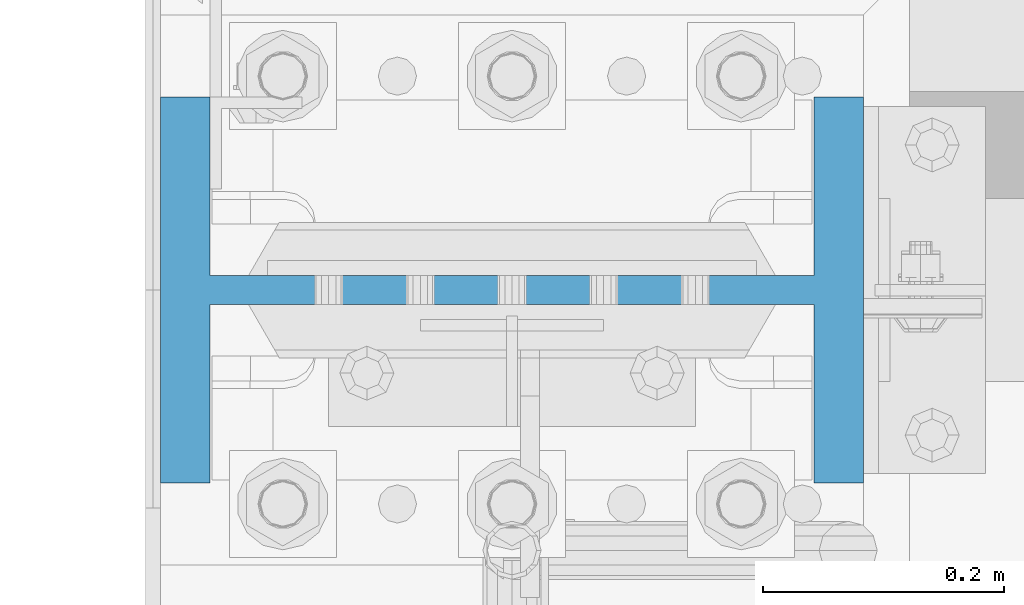
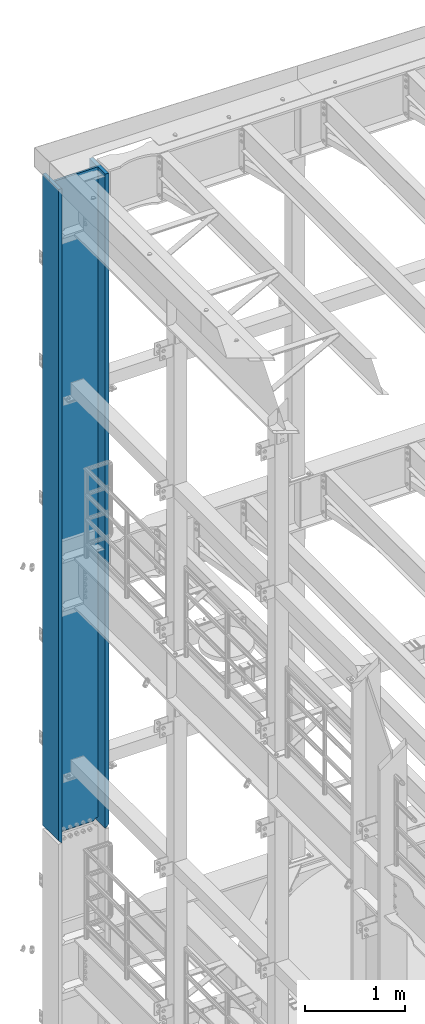
# One storey, part 749 of 1876: 1 column, 1 element without a shape of its own.
"""IFC2X3 building model written with IfcOpenShell, lengths in millimetres."""

from ifc_helpers import new_model, si_unit, frame, origin_with_axes, place, context, subcontext, project, spatial, faceted_brep, material, type_object, element, aggregate, save


model = new_model("IFC2X3")

# Units and contexts
model_context = context("Model", 3, precision=1e-05, world=origin_with_axes())
body_context = subcontext(model_context, "Body", "Model", "MODEL_VIEW")
ifc_project = project(units=[si_unit("LENGTHUNIT", "METRE", prefix="MILLI"), si_unit("AREAUNIT", "SQUARE_METRE"), si_unit("VOLUMEUNIT", "CUBIC_METRE"), si_unit("MASSUNIT", "GRAM", prefix="KILO"), si_unit("TIMEUNIT", "SECOND"), si_unit("PLANEANGLEUNIT", "RADIAN"), si_unit("SOLIDANGLEUNIT", "STERADIAN"), si_unit("THERMODYNAMICTEMPERATUREUNIT", "DEGREE_CELSIUS"), si_unit("LUMINOUSINTENSITYUNIT", "LUMEN")], contexts=[model_context])

# Site, building, storey
site_placement = place(None, origin_with_axes())
site = spatial("IfcSite", under=ifc_project, at=site_placement, CompositionType="ELEMENT")
building_placement = place(site_placement, origin_with_axes())
building = spatial("IfcBuilding", under=site, at=building_placement, Name="Undefined", CompositionType="ELEMENT")
storey_placement = place(building_placement, origin_with_axes())
storey = spatial("IfcBuildingStorey", under=building, at=storey_placement, Name="Undefined", CompositionType="ELEMENT", Elevation=0.0)

# Assembly, column
assembly_placement = place(storey_placement, origin_with_axes())
assembly = element("IfcElementAssembly", 1, at=assembly_placement, inside=storey, Name="COLUMN", AssemblyPlace="NOTDEFINED", PredefinedType="RIGID_FRAME")
ifc_material = material(Name="STEEL/A992")
column_type = type_object("IfcColumnType", Name="W21X201", PredefinedType="NOTDEFINED")
column_placement = place(assembly_placement, frame((0.0, 13716.0, 14528.8), z_axis=(-1.0, 0.0, 0.0), x_axis=(0.0, 0.0, 1.0)))
column = element("IfcColumn", 2, at=column_placement, type_object=column_type, material=ifc_material, Name="COLUMN", ObjectType="W21X201", context=body_context, shape_type="Brep", body=[
    faceted_brep([(26.9875007629398, -11.9062500000018, 204.691852352942), (25.7903180721823, -10.7090673092443, 203.891920453292), (6.35000000000036, 8.73125076293763, 200.02500076294), (6.35000000000036, 8.73125076293763, -200.02500076294), (25.7903188351211, -10.7090680721831, -203.891920453292), (26.9875007629398, -11.90625, -204.691851843163), (42.2710247077357, -11.90625, -214.903976055204), (42.2710247077357, 11.90625, -214.903976055204), (53.2830803096476, 11.90625, -231.384681927818), (53.2830803096476, -11.90625, -231.384681927818), (8026.4, -160.3375, 292.1), (8026.4, 160.3375, 292.1), (44.4500000000007, 160.3375, 292.1), (44.4500000000007, -160.3375, 292.1), (6.35000000000036, -160.3375, 250.825), (57.1499992370609, -160.3375, 250.825), (8026.4, -160.3375, 250.825), (6.35000000000036, -160.3375, 254.0), (6.35000000000036, -11.90625, 250.825), (6.35000000000036, 160.3375, 254.0), (6.35000000000036, 160.3375, 250.825), (6.35000000000036, 11.90625, 250.825), (6.35000000000036, 8.73125076293763, 250.825), (8026.4, 160.3375, 250.825), (57.1499992370609, 160.3375, 250.825), (57.1499992370609, 11.90625, 250.825), (8026.4, 11.90625, 250.825), (57.1499992370609, -11.90625, 250.825000000001), (53.2830795467089, 11.90625, 231.384681927818), (53.2830795467089, -11.90625, 231.384681927818), (26.9875007629398, -11.90625, 250.825), (8026.4, -11.90625, 250.825), (57.1499999999996, 160.3375, -250.825), (6.35000000000036, 160.3375, -250.825), (6.35000000000036, 11.90625, -250.825), (57.1499999999996, 11.90625, -250.825), (8026.4, 11.90625, -250.825), (8026.4, 160.3375, -250.825), (8026.4, 160.3375, -292.1), (8026.4, -160.3375, -292.1), (44.4500000000007, -160.3375, -292.1), (44.4500000000007, 160.3375, -292.1), (8026.4, -160.3375, -250.825), (57.1499999999996, -160.3375, -250.825), (6.35000000000036, -160.3375, -250.825), (6.35000000000036, -160.3375, -254.000000000001), (6.35000000000036, 160.3375, -254.000000000001), (8026.4, -11.90625, -250.825), (57.1499999999996, -11.90625, -250.825000000001), (26.9875007629398, -11.90625, -250.825), (6.35000000000036, -11.90625, -250.825), (6.35000000000036, 8.73125076293763, -250.825), (25.7903188351211, 11.90625, -203.891920453292), (6.35000000000036, 11.90625, -200.02500076294), (6.35000000000036, 11.90625, 200.02500076294), (25.7903180721823, 11.90625, 203.891920453292), (42.271023944797, 11.90625, 214.903976055204), (42.271023944797, -11.90625, 214.903976055204)], [[[0, 1, 2, 3, 4, 5]], [[6, 7, 8, 9]], [[10, 11, 12, 13]], [[14, 15, 16, 10, 13, 17]], [[18, 14, 17, 19, 20, 21, 22]], [[13, 12, 19, 17]], [[11, 23, 24, 20, 19, 12]], [[25, 21, 20, 24, 23, 26]], [[27, 25, 28, 29]], [[30, 18, 22, 21, 25, 27]], [[15, 14, 18, 30, 27, 31, 16]], [[32, 33, 34, 35, 36, 37]], [[38, 39, 40, 41]], [[39, 42, 43, 44, 45, 40]], [[40, 45, 46, 41]], [[33, 32, 37, 38, 41, 46]], [[36, 26, 23, 11, 10, 16, 31, 47, 42, 39, 38, 37]], [[48, 49, 50, 44, 43, 42, 47]], [[34, 33, 46, 45, 44, 50, 51]], [[49, 48, 35, 34, 51, 50]], [[9, 8, 35, 48]], [[7, 52, 53, 54, 55, 56, 28, 25, 26, 36, 35, 8]], [[29, 28, 56, 57]], [[6, 9, 48, 47, 31, 27, 29, 57, 0, 5]], [[52, 7, 6, 5, 4]], [[53, 52, 4, 3]], [[54, 53, 3, 2]], [[55, 54, 2, 1]], [[57, 56, 55, 1, 0]]]),
])
aggregate(assembly, [column])

save(model, "model.ifc")
